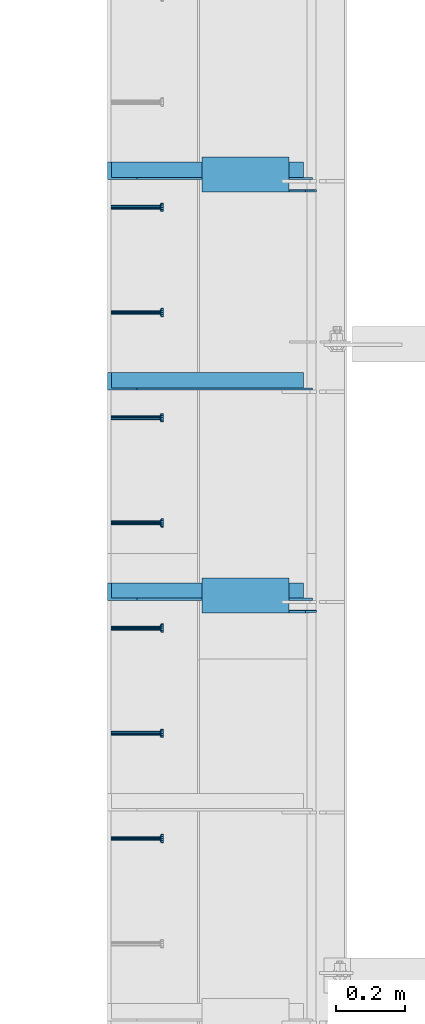
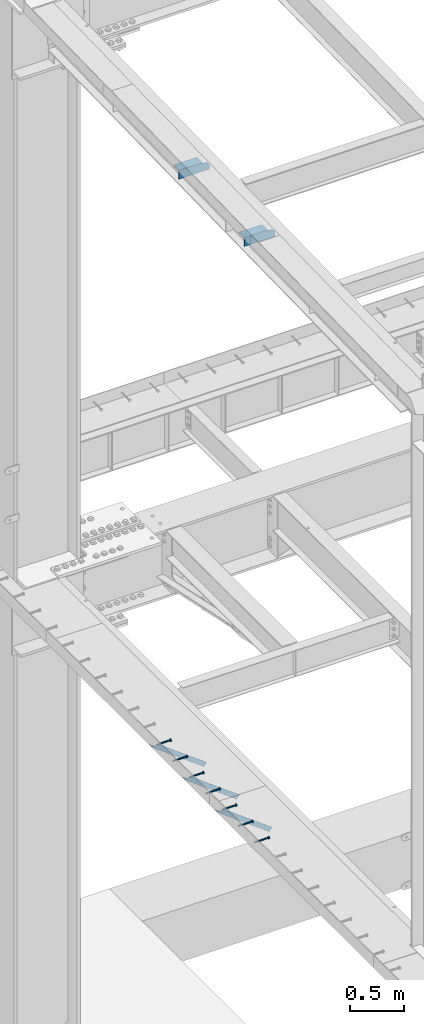
# One storey, part 1330 of 1763: 9 beams, 3 members, 9 elements without a shape of their own.
"""IFC2X3 building model written with IfcOpenShell, lengths in millimetres."""

from ifc_helpers import new_model, si_unit, frame, origin_with_axes, place, context, subcontext, project, spatial, faceted_brep, material, type_object, element, aggregate, save


model = new_model("IFC2X3")

# Units and contexts
model_context = context("Model", 3, precision=1e-05, world=origin_with_axes())
body_context = subcontext(model_context, "Body", "Model", "MODEL_VIEW")
ifc_project = project(units=[si_unit("LENGTHUNIT", "METRE", prefix="MILLI"), si_unit("AREAUNIT", "SQUARE_METRE"), si_unit("VOLUMEUNIT", "CUBIC_METRE"), si_unit("MASSUNIT", "GRAM", prefix="KILO"), si_unit("TIMEUNIT", "SECOND"), si_unit("PLANEANGLEUNIT", "RADIAN"), si_unit("SOLIDANGLEUNIT", "STERADIAN"), si_unit("THERMODYNAMICTEMPERATUREUNIT", "DEGREE_CELSIUS"), si_unit("LUMINOUSINTENSITYUNIT", "LUMEN")], contexts=[model_context])

# Site, building, storey
site_placement = place(None, origin_with_axes())
site = spatial("IfcSite", under=ifc_project, at=site_placement, CompositionType="ELEMENT")
building_placement = place(site_placement, origin_with_axes())
building = spatial("IfcBuilding", under=site, at=building_placement, Name="Undefined", CompositionType="ELEMENT")
storey_placement = place(building_placement, origin_with_axes())
storey = spatial("IfcBuildingStorey", under=building, at=storey_placement, Name="Undefined", CompositionType="ELEMENT", Elevation=0.0)

# Assembly, beam
assembly_1_placement = place(storey_placement, origin_with_axes())
assembly_1 = element("IfcElementAssembly", 1, at=assembly_1_placement, inside=storey, Name="HEADED STUD ANCHOR", AssemblyPlace="NOTDEFINED", PredefinedType="RIGID_FRAME")
ifc_material_1 = material(Name="STEEL/A108")
beam_type_1 = type_object("IfcBeamType", PredefinedType="NOTDEFINED")
beam_1_placement = place(assembly_1_placement, frame((-87975.5122736983, 47031.2750061035, 5268.91250001202), z_axis=(0.0, 0.0, -1.0), x_axis=(1.0, 0.0, 0.0)))
beam_1 = element("IfcBeam", 2, at=beam_1_placement, type_object=beam_type_1, material=ifc_material_1, Name="HEADED STUD ANCHOR", context=body_context, shape_type="Brep", body=[
    faceted_brep([(0.0, -3.1800000667572, 5.5), (0.0, -5.5, 3.1800000667572), (141.732000000002, -5.5, 3.1800000667572), (141.732000000002, -3.1800000667572, 5.5), (0.0, -6.34999999999491, 1.45519152283669e-11), (141.732000000002, -6.34999990463257, 0.0), (0.0, -5.5, -3.1800000667572), (141.732000000002, -5.5, -3.1800000667572), (0.0, -3.1800000667572, -5.5), (141.732000000002, -3.1800000667572, -5.5), (0.0, 0.0, -6.34999990463257), (141.732000000002, 0.0, -6.34999990463257), (0.0, 3.1800000667572, -5.5), (141.732000000002, 3.1800000667572, -5.5), (0.0, 5.5, -3.1800000667572), (141.732000000002, 5.5, -3.1800000667572), (0.0, 6.34999999999491, -2.91038304567337e-11), (141.732000000002, 6.34999990463257, 0.0), (0.0, 5.5, 3.1800000667572), (141.732000000002, 5.5, 3.1800000667572), (0.0, 3.1800000667572, 5.5), (141.732000000002, 3.1800000667572, 5.5), (0.0, 0.0, 6.34999990463257), (141.732000000002, 0.0, 6.34999990463257), (144.780000000001, -10.9899997711182, 6.34999990463257), (144.780000000001, -6.34000015258789, 10.9899997711182), (144.780000000001, -12.6999998092651, 0.0), (144.780000000001, -10.9899997711182, -6.34999990463257), (144.780000000001, -6.34000015258789, -10.9899997711182), (144.780000000001, 0.0, -12.6899995803833), (144.780000000001, 6.34000015258789, -10.9899997711182), (144.780000000001, 10.9899997711182, -6.34999990463257), (144.780000000001, 12.6999998092651, 0.0), (144.780000000001, 10.9899997711182, 6.34999990463257), (144.780000000001, 6.34000015258789, 10.9899997711182), (144.780000000001, 0.0, 12.6899995803833), (152.400000000001, -10.9899997711182, 6.34999990463257), (152.400000000001, -6.34000015258789, 10.9899997711182), (152.400000000001, -12.6999998092651, 0.0), (152.400000000001, -10.9899997711182, -6.34999990463257), (152.400000000001, -6.34000015258789, -10.9899997711182), (152.400000000001, 0.0, -12.6899995803833), (152.400000000001, 6.34000015258789, -10.9899997711182), (152.400000000001, 10.9899997711182, -6.34999990463257), (152.400000000001, 12.6999998092651, 0.0), (152.400000000001, 10.9899997711182, 6.34999990463257), (152.400000000001, 6.34000015258789, 10.9899997711182), (152.400000000001, 0.0, 12.6899995803833)], [[[0, 1, 2, 3]], [[1, 4, 5, 2]], [[4, 6, 7, 5]], [[6, 8, 9, 7]], [[8, 10, 11, 9]], [[10, 12, 13, 11]], [[12, 14, 15, 13]], [[14, 16, 17, 15]], [[16, 18, 19, 17]], [[18, 20, 21, 19]], [[20, 22, 23, 21]], [[22, 0, 3, 23]], [[22, 20, 18, 16, 14, 12, 10, 8, 6, 4, 1, 0]], [[3, 2, 24, 25]], [[2, 5, 26, 24]], [[5, 7, 27, 26]], [[7, 9, 28, 27]], [[9, 11, 29, 28]], [[11, 13, 30, 29]], [[13, 15, 31, 30]], [[15, 17, 32, 31]], [[17, 19, 33, 32]], [[19, 21, 34, 33]], [[21, 23, 35, 34]], [[23, 3, 25, 35]], [[25, 24, 36, 37]], [[24, 26, 38, 36]], [[26, 27, 39, 38]], [[27, 28, 40, 39]], [[28, 29, 41, 40]], [[29, 30, 42, 41]], [[30, 31, 43, 42]], [[31, 32, 44, 43]], [[32, 33, 45, 44]], [[33, 34, 46, 45]], [[34, 35, 47, 46]], [[35, 25, 37, 47]], [[38, 39, 40, 41, 42, 43, 44, 45, 46, 47, 37, 36]]]),
])
aggregate(assembly_1, [beam_1])

assembly_2_placement = place(storey_placement, origin_with_axes())
assembly_2 = element("IfcElementAssembly", 3, at=assembly_2_placement, inside=storey, Name="HEADED STUD ANCHOR", AssemblyPlace="NOTDEFINED", PredefinedType="RIGID_FRAME")
beam_2_placement = place(assembly_2_placement, frame((-87975.5122736983, 47336.0750061035, 5268.91250001202), z_axis=(0.0, 0.0, -1.0), x_axis=(1.0, 0.0, 0.0)))
beam_2 = element("IfcBeam", 4, at=beam_2_placement, type_object=beam_type_1, material=ifc_material_1, Name="HEADED STUD ANCHOR", context=body_context, shape_type="Brep", body=[
    faceted_brep([(0.0, -3.1800000667572, 5.5), (0.0, -5.5, 3.1800000667572), (141.732000000002, -5.5, 3.1800000667572), (141.732000000002, -3.1800000667572, 5.5), (0.0, -6.34999999999491, 1.45519152283669e-11), (141.732000000002, -6.34999990463257, 0.0), (0.0, -5.5, -3.1800000667572), (141.732000000002, -5.5, -3.1800000667572), (0.0, -3.1800000667572, -5.5), (141.732000000002, -3.1800000667572, -5.5), (0.0, 0.0, -6.34999990463257), (141.732000000002, 0.0, -6.34999990463257), (0.0, 3.1800000667572, -5.5), (141.732000000002, 3.1800000667572, -5.5), (0.0, 5.5, -3.1800000667572), (141.732000000002, 5.5, -3.1800000667572), (0.0, 6.34999999999491, -2.91038304567337e-11), (141.732000000002, 6.34999990463257, 0.0), (0.0, 5.5, 3.1800000667572), (141.732000000002, 5.5, 3.1800000667572), (0.0, 3.1800000667572, 5.5), (141.732000000002, 3.1800000667572, 5.5), (0.0, 0.0, 6.34999990463257), (141.732000000002, 0.0, 6.34999990463257), (144.780000000001, -10.9899997711182, 6.34999990463257), (144.780000000001, -6.34000015258789, 10.9899997711182), (144.780000000001, -12.6999998092651, 0.0), (144.780000000001, -10.9899997711182, -6.34999990463257), (144.780000000001, -6.34000015258789, -10.9899997711182), (144.780000000001, 0.0, -12.6899995803833), (144.780000000001, 6.34000015258789, -10.9899997711182), (144.780000000001, 10.9899997711182, -6.34999990463257), (144.780000000001, 12.6999998092651, 0.0), (144.780000000001, 10.9899997711182, 6.34999990463257), (144.780000000001, 6.34000015258789, 10.9899997711182), (144.780000000001, 0.0, 12.6899995803833), (152.400000000001, -10.9899997711182, 6.34999990463257), (152.400000000001, -6.34000015258789, 10.9899997711182), (152.400000000001, -12.6999998092651, 0.0), (152.400000000001, -10.9899997711182, -6.34999990463257), (152.400000000001, -6.34000015258789, -10.9899997711182), (152.400000000001, 0.0, -12.6899995803833), (152.400000000001, 6.34000015258789, -10.9899997711182), (152.400000000001, 10.9899997711182, -6.34999990463257), (152.400000000001, 12.6999998092651, 0.0), (152.400000000001, 10.9899997711182, 6.34999990463257), (152.400000000001, 6.34000015258789, 10.9899997711182), (152.400000000001, 0.0, 12.6899995803833)], [[[0, 1, 2, 3]], [[1, 4, 5, 2]], [[4, 6, 7, 5]], [[6, 8, 9, 7]], [[8, 10, 11, 9]], [[10, 12, 13, 11]], [[12, 14, 15, 13]], [[14, 16, 17, 15]], [[16, 18, 19, 17]], [[18, 20, 21, 19]], [[20, 22, 23, 21]], [[22, 0, 3, 23]], [[22, 20, 18, 16, 14, 12, 10, 8, 6, 4, 1, 0]], [[3, 2, 24, 25]], [[2, 5, 26, 24]], [[5, 7, 27, 26]], [[7, 9, 28, 27]], [[9, 11, 29, 28]], [[11, 13, 30, 29]], [[13, 15, 31, 30]], [[15, 17, 32, 31]], [[17, 19, 33, 32]], [[19, 21, 34, 33]], [[21, 23, 35, 34]], [[23, 3, 25, 35]], [[25, 24, 36, 37]], [[24, 26, 38, 36]], [[26, 27, 39, 38]], [[27, 28, 40, 39]], [[28, 29, 41, 40]], [[29, 30, 42, 41]], [[30, 31, 43, 42]], [[31, 32, 44, 43]], [[32, 33, 45, 44]], [[33, 34, 46, 45]], [[34, 35, 47, 46]], [[35, 25, 37, 47]], [[38, 39, 40, 41, 42, 43, 44, 45, 46, 47, 37, 36]]]),
])
aggregate(assembly_2, [beam_2])

assembly_3_placement = place(storey_placement, origin_with_axes())
assembly_3 = element("IfcElementAssembly", 5, at=assembly_3_placement, inside=storey, Name="HEADED STUD ANCHOR", AssemblyPlace="NOTDEFINED", PredefinedType="RIGID_FRAME")
beam_3_placement = place(assembly_3_placement, frame((-87975.5122736983, 47640.8750061035, 5268.91250001202), z_axis=(0.0, 0.0, -1.0), x_axis=(1.0, 0.0, 0.0)))
beam_3 = element("IfcBeam", 6, at=beam_3_placement, type_object=beam_type_1, material=ifc_material_1, Name="HEADED STUD ANCHOR", context=body_context, shape_type="Brep", body=[
    faceted_brep([(0.0, -3.1800000667572, 5.5), (0.0, -5.5, 3.1800000667572), (141.732000000002, -5.5, 3.1800000667572), (141.732000000002, -3.1800000667572, 5.5), (0.0, -6.34999999999491, 1.45519152283669e-11), (141.732000000002, -6.34999990463257, 0.0), (0.0, -5.5, -3.1800000667572), (141.732000000002, -5.5, -3.1800000667572), (0.0, -3.1800000667572, -5.5), (141.732000000002, -3.1800000667572, -5.5), (0.0, 0.0, -6.34999990463257), (141.732000000002, 0.0, -6.34999990463257), (0.0, 3.1800000667572, -5.5), (141.732000000002, 3.1800000667572, -5.5), (0.0, 5.5, -3.1800000667572), (141.732000000002, 5.5, -3.1800000667572), (0.0, 6.34999999999491, -2.91038304567337e-11), (141.732000000002, 6.34999990463257, 0.0), (0.0, 5.5, 3.1800000667572), (141.732000000002, 5.5, 3.1800000667572), (0.0, 3.1800000667572, 5.5), (141.732000000002, 3.1800000667572, 5.5), (0.0, 0.0, 6.34999990463257), (141.732000000002, 0.0, 6.34999990463257), (144.780000000001, -10.9899997711182, 6.34999990463257), (144.780000000001, -6.34000015258789, 10.9899997711182), (144.780000000001, -12.6999998092651, 0.0), (144.780000000001, -10.9899997711182, -6.34999990463257), (144.780000000001, -6.34000015258789, -10.9899997711182), (144.780000000001, 0.0, -12.6899995803833), (144.780000000001, 6.34000015258789, -10.9899997711182), (144.780000000001, 10.9899997711182, -6.34999990463257), (144.780000000001, 12.6999998092651, 0.0), (144.780000000001, 10.9899997711182, 6.34999990463257), (144.780000000001, 6.34000015258789, 10.9899997711182), (144.780000000001, 0.0, 12.6899995803833), (152.400000000001, -10.9899997711182, 6.34999990463257), (152.400000000001, -6.34000015258789, 10.9899997711182), (152.400000000001, -12.6999998092651, 0.0), (152.400000000001, -10.9899997711182, -6.34999990463257), (152.400000000001, -6.34000015258789, -10.9899997711182), (152.400000000001, 0.0, -12.6899995803833), (152.400000000001, 6.34000015258789, -10.9899997711182), (152.400000000001, 10.9899997711182, -6.34999990463257), (152.400000000001, 12.6999998092651, 0.0), (152.400000000001, 10.9899997711182, 6.34999990463257), (152.400000000001, 6.34000015258789, 10.9899997711182), (152.400000000001, 0.0, 12.6899995803833)], [[[0, 1, 2, 3]], [[1, 4, 5, 2]], [[4, 6, 7, 5]], [[6, 8, 9, 7]], [[8, 10, 11, 9]], [[10, 12, 13, 11]], [[12, 14, 15, 13]], [[14, 16, 17, 15]], [[16, 18, 19, 17]], [[18, 20, 21, 19]], [[20, 22, 23, 21]], [[22, 0, 3, 23]], [[22, 20, 18, 16, 14, 12, 10, 8, 6, 4, 1, 0]], [[3, 2, 24, 25]], [[2, 5, 26, 24]], [[5, 7, 27, 26]], [[7, 9, 28, 27]], [[9, 11, 29, 28]], [[11, 13, 30, 29]], [[13, 15, 31, 30]], [[15, 17, 32, 31]], [[17, 19, 33, 32]], [[19, 21, 34, 33]], [[21, 23, 35, 34]], [[23, 3, 25, 35]], [[25, 24, 36, 37]], [[24, 26, 38, 36]], [[26, 27, 39, 38]], [[27, 28, 40, 39]], [[28, 29, 41, 40]], [[29, 30, 42, 41]], [[30, 31, 43, 42]], [[31, 32, 44, 43]], [[32, 33, 45, 44]], [[33, 34, 46, 45]], [[34, 35, 47, 46]], [[35, 25, 37, 47]], [[38, 39, 40, 41, 42, 43, 44, 45, 46, 47, 37, 36]]]),
])
aggregate(assembly_3, [beam_3])

assembly_4_placement = place(storey_placement, origin_with_axes())
assembly_4 = element("IfcElementAssembly", 7, at=assembly_4_placement, inside=storey, Name="HEADED STUD ANCHOR", AssemblyPlace="NOTDEFINED", PredefinedType="RIGID_FRAME")
beam_4_placement = place(assembly_4_placement, frame((-87975.5122736983, 47945.6750061035, 5268.91250001202), z_axis=(0.0, 0.0, -1.0), x_axis=(1.0, 0.0, 0.0)))
beam_4 = element("IfcBeam", 8, at=beam_4_placement, type_object=beam_type_1, material=ifc_material_1, Name="HEADED STUD ANCHOR", context=body_context, shape_type="Brep", body=[
    faceted_brep([(0.0, -3.1800000667572, 5.5), (0.0, -5.5, 3.1800000667572), (141.732000000002, -5.5, 3.1800000667572), (141.732000000002, -3.1800000667572, 5.5), (0.0, -6.34999999999491, 1.45519152283669e-11), (141.732000000002, -6.34999990463257, 0.0), (0.0, -5.5, -3.1800000667572), (141.732000000002, -5.5, -3.1800000667572), (0.0, -3.1800000667572, -5.5), (141.732000000002, -3.1800000667572, -5.5), (0.0, 0.0, -6.34999990463257), (141.732000000002, 0.0, -6.34999990463257), (0.0, 3.1800000667572, -5.5), (141.732000000002, 3.1800000667572, -5.5), (0.0, 5.5, -3.1800000667572), (141.732000000002, 5.5, -3.1800000667572), (0.0, 6.34999999999491, -2.91038304567337e-11), (141.732000000002, 6.34999990463257, 0.0), (0.0, 5.5, 3.1800000667572), (141.732000000002, 5.5, 3.1800000667572), (0.0, 3.1800000667572, 5.5), (141.732000000002, 3.1800000667572, 5.5), (0.0, 0.0, 6.34999990463257), (141.732000000002, 0.0, 6.34999990463257), (144.780000000001, -10.9899997711182, 6.34999990463257), (144.780000000001, -6.34000015258789, 10.9899997711182), (144.780000000001, -12.6999998092651, 0.0), (144.780000000001, -10.9899997711182, -6.34999990463257), (144.780000000001, -6.34000015258789, -10.9899997711182), (144.780000000001, 0.0, -12.6899995803833), (144.780000000001, 6.34000015258789, -10.9899997711182), (144.780000000001, 10.9899997711182, -6.34999990463257), (144.780000000001, 12.6999998092651, 0.0), (144.780000000001, 10.9899997711182, 6.34999990463257), (144.780000000001, 6.34000015258789, 10.9899997711182), (144.780000000001, 0.0, 12.6899995803833), (152.400000000001, -10.9899997711182, 6.34999990463257), (152.400000000001, -6.34000015258789, 10.9899997711182), (152.400000000001, -12.6999998092651, 0.0), (152.400000000001, -10.9899997711182, -6.34999990463257), (152.400000000001, -6.34000015258789, -10.9899997711182), (152.400000000001, 0.0, -12.6899995803833), (152.400000000001, 6.34000015258789, -10.9899997711182), (152.400000000001, 10.9899997711182, -6.34999990463257), (152.400000000001, 12.6999998092651, 0.0), (152.400000000001, 10.9899997711182, 6.34999990463257), (152.400000000001, 6.34000015258789, 10.9899997711182), (152.400000000001, 0.0, 12.6899995803833)], [[[0, 1, 2, 3]], [[1, 4, 5, 2]], [[4, 6, 7, 5]], [[6, 8, 9, 7]], [[8, 10, 11, 9]], [[10, 12, 13, 11]], [[12, 14, 15, 13]], [[14, 16, 17, 15]], [[16, 18, 19, 17]], [[18, 20, 21, 19]], [[20, 22, 23, 21]], [[22, 0, 3, 23]], [[22, 20, 18, 16, 14, 12, 10, 8, 6, 4, 1, 0]], [[3, 2, 24, 25]], [[2, 5, 26, 24]], [[5, 7, 27, 26]], [[7, 9, 28, 27]], [[9, 11, 29, 28]], [[11, 13, 30, 29]], [[13, 15, 31, 30]], [[15, 17, 32, 31]], [[17, 19, 33, 32]], [[19, 21, 34, 33]], [[21, 23, 35, 34]], [[23, 3, 25, 35]], [[25, 24, 36, 37]], [[24, 26, 38, 36]], [[26, 27, 39, 38]], [[27, 28, 40, 39]], [[28, 29, 41, 40]], [[29, 30, 42, 41]], [[30, 31, 43, 42]], [[31, 32, 44, 43]], [[32, 33, 45, 44]], [[33, 34, 46, 45]], [[34, 35, 47, 46]], [[35, 25, 37, 47]], [[38, 39, 40, 41, 42, 43, 44, 45, 46, 47, 37, 36]]]),
])
aggregate(assembly_4, [beam_4])

assembly_5_placement = place(storey_placement, origin_with_axes())
assembly_5 = element("IfcElementAssembly", 9, at=assembly_5_placement, inside=storey, Name="HEADED STUD ANCHOR", AssemblyPlace="NOTDEFINED", PredefinedType="RIGID_FRAME")
beam_5_placement = place(assembly_5_placement, frame((-87975.5122736983, 48250.4750061035, 5268.91250001202), z_axis=(0.0, 0.0, -1.0), x_axis=(1.0, 0.0, 0.0)))
beam_5 = element("IfcBeam", 10, at=beam_5_placement, type_object=beam_type_1, material=ifc_material_1, Name="HEADED STUD ANCHOR", context=body_context, shape_type="Brep", body=[
    faceted_brep([(0.0, -3.1800000667572, 5.5), (0.0, -5.5, 3.1800000667572), (141.732000000002, -5.5, 3.1800000667572), (141.732000000002, -3.1800000667572, 5.5), (0.0, -6.34999999999491, 1.45519152283669e-11), (141.732000000002, -6.34999990463257, 0.0), (0.0, -5.5, -3.1800000667572), (141.732000000002, -5.5, -3.1800000667572), (0.0, -3.1800000667572, -5.5), (141.732000000002, -3.1800000667572, -5.5), (0.0, 0.0, -6.34999990463257), (141.732000000002, 0.0, -6.34999990463257), (0.0, 3.1800000667572, -5.5), (141.732000000002, 3.1800000667572, -5.5), (0.0, 5.5, -3.1800000667572), (141.732000000002, 5.5, -3.1800000667572), (0.0, 6.34999999999491, -2.91038304567337e-11), (141.732000000002, 6.34999990463257, 0.0), (0.0, 5.5, 3.1800000667572), (141.732000000002, 5.5, 3.1800000667572), (0.0, 3.1800000667572, 5.5), (141.732000000002, 3.1800000667572, 5.5), (0.0, 0.0, 6.34999990463257), (141.732000000002, 0.0, 6.34999990463257), (144.780000000001, -10.9899997711182, 6.34999990463257), (144.780000000001, -6.34000015258789, 10.9899997711182), (144.780000000001, -12.6999998092651, 0.0), (144.780000000001, -10.9899997711182, -6.34999990463257), (144.780000000001, -6.34000015258789, -10.9899997711182), (144.780000000001, 0.0, -12.6899995803833), (144.780000000001, 6.34000015258789, -10.9899997711182), (144.780000000001, 10.9899997711182, -6.34999990463257), (144.780000000001, 12.6999998092651, 0.0), (144.780000000001, 10.9899997711182, 6.34999990463257), (144.780000000001, 6.34000015258789, 10.9899997711182), (144.780000000001, 0.0, 12.6899995803833), (152.400000000001, -10.9899997711182, 6.34999990463257), (152.400000000001, -6.34000015258789, 10.9899997711182), (152.400000000001, -12.6999998092651, 0.0), (152.400000000001, -10.9899997711182, -6.34999990463257), (152.400000000001, -6.34000015258789, -10.9899997711182), (152.400000000001, 0.0, -12.6899995803833), (152.400000000001, 6.34000015258789, -10.9899997711182), (152.400000000001, 10.9899997711182, -6.34999990463257), (152.400000000001, 12.6999998092651, 0.0), (152.400000000001, 10.9899997711182, 6.34999990463257), (152.400000000001, 6.34000015258789, 10.9899997711182), (152.400000000001, 0.0, 12.6899995803833)], [[[0, 1, 2, 3]], [[1, 4, 5, 2]], [[4, 6, 7, 5]], [[6, 8, 9, 7]], [[8, 10, 11, 9]], [[10, 12, 13, 11]], [[12, 14, 15, 13]], [[14, 16, 17, 15]], [[16, 18, 19, 17]], [[18, 20, 21, 19]], [[20, 22, 23, 21]], [[22, 0, 3, 23]], [[22, 20, 18, 16, 14, 12, 10, 8, 6, 4, 1, 0]], [[3, 2, 24, 25]], [[2, 5, 26, 24]], [[5, 7, 27, 26]], [[7, 9, 28, 27]], [[9, 11, 29, 28]], [[11, 13, 30, 29]], [[13, 15, 31, 30]], [[15, 17, 32, 31]], [[17, 19, 33, 32]], [[19, 21, 34, 33]], [[21, 23, 35, 34]], [[23, 3, 25, 35]], [[25, 24, 36, 37]], [[24, 26, 38, 36]], [[26, 27, 39, 38]], [[27, 28, 40, 39]], [[28, 29, 41, 40]], [[29, 30, 42, 41]], [[30, 31, 43, 42]], [[31, 32, 44, 43]], [[32, 33, 45, 44]], [[33, 34, 46, 45]], [[34, 35, 47, 46]], [[35, 25, 37, 47]], [[38, 39, 40, 41, 42, 43, 44, 45, 46, 47, 37, 36]]]),
])
aggregate(assembly_5, [beam_5])

assembly_6_placement = place(storey_placement, origin_with_axes())
assembly_6 = element("IfcElementAssembly", 11, at=assembly_6_placement, inside=storey, Name="HEADED STUD ANCHOR", AssemblyPlace="NOTDEFINED", PredefinedType="RIGID_FRAME")
beam_6_placement = place(assembly_6_placement, frame((-87975.5122736983, 48555.2750061035, 5268.91250001202), z_axis=(0.0, 0.0, -1.0), x_axis=(1.0, 0.0, 0.0)))
beam_6 = element("IfcBeam", 12, at=beam_6_placement, type_object=beam_type_1, material=ifc_material_1, Name="HEADED STUD ANCHOR", context=body_context, shape_type="Brep", body=[
    faceted_brep([(0.0, -3.1800000667572, 5.5), (0.0, -5.5, 3.1800000667572), (141.732000000002, -5.5, 3.1800000667572), (141.732000000002, -3.1800000667572, 5.5), (0.0, -6.34999999999491, 1.45519152283669e-11), (141.732000000002, -6.34999990463257, 0.0), (0.0, -5.5, -3.1800000667572), (141.732000000002, -5.5, -3.1800000667572), (0.0, -3.1800000667572, -5.5), (141.732000000002, -3.1800000667572, -5.5), (0.0, 0.0, -6.34999990463257), (141.732000000002, 0.0, -6.34999990463257), (0.0, 3.1800000667572, -5.5), (141.732000000002, 3.1800000667572, -5.5), (0.0, 5.5, -3.1800000667572), (141.732000000002, 5.5, -3.1800000667572), (0.0, 6.34999999999491, -2.91038304567337e-11), (141.732000000002, 6.34999990463257, 0.0), (0.0, 5.5, 3.1800000667572), (141.732000000002, 5.5, 3.1800000667572), (0.0, 3.1800000667572, 5.5), (141.732000000002, 3.1800000667572, 5.5), (0.0, 0.0, 6.34999990463257), (141.732000000002, 0.0, 6.34999990463257), (144.780000000001, -10.9899997711182, 6.34999990463257), (144.780000000001, -6.34000015258789, 10.9899997711182), (144.780000000001, -12.6999998092651, 0.0), (144.780000000001, -10.9899997711182, -6.34999990463257), (144.780000000001, -6.34000015258789, -10.9899997711182), (144.780000000001, 0.0, -12.6899995803833), (144.780000000001, 6.34000015258789, -10.9899997711182), (144.780000000001, 10.9899997711182, -6.34999990463257), (144.780000000001, 12.6999998092651, 0.0), (144.780000000001, 10.9899997711182, 6.34999990463257), (144.780000000001, 6.34000015258789, 10.9899997711182), (144.780000000001, 0.0, 12.6899995803833), (152.400000000001, -10.9899997711182, 6.34999990463257), (152.400000000001, -6.34000015258789, 10.9899997711182), (152.400000000001, -12.6999998092651, 0.0), (152.400000000001, -10.9899997711182, -6.34999990463257), (152.400000000001, -6.34000015258789, -10.9899997711182), (152.400000000001, 0.0, -12.6899995803833), (152.400000000001, 6.34000015258789, -10.9899997711182), (152.400000000001, 10.9899997711182, -6.34999990463257), (152.400000000001, 12.6999998092651, 0.0), (152.400000000001, 10.9899997711182, 6.34999990463257), (152.400000000001, 6.34000015258789, 10.9899997711182), (152.400000000001, 0.0, 12.6899995803833)], [[[0, 1, 2, 3]], [[1, 4, 5, 2]], [[4, 6, 7, 5]], [[6, 8, 9, 7]], [[8, 10, 11, 9]], [[10, 12, 13, 11]], [[12, 14, 15, 13]], [[14, 16, 17, 15]], [[16, 18, 19, 17]], [[18, 20, 21, 19]], [[20, 22, 23, 21]], [[22, 0, 3, 23]], [[22, 20, 18, 16, 14, 12, 10, 8, 6, 4, 1, 0]], [[3, 2, 24, 25]], [[2, 5, 26, 24]], [[5, 7, 27, 26]], [[7, 9, 28, 27]], [[9, 11, 29, 28]], [[11, 13, 30, 29]], [[13, 15, 31, 30]], [[15, 17, 32, 31]], [[17, 19, 33, 32]], [[19, 21, 34, 33]], [[21, 23, 35, 34]], [[23, 3, 25, 35]], [[25, 24, 36, 37]], [[24, 26, 38, 36]], [[26, 27, 39, 38]], [[27, 28, 40, 39]], [[28, 29, 41, 40]], [[29, 30, 42, 41]], [[30, 31, 43, 42]], [[31, 32, 44, 43]], [[32, 33, 45, 44]], [[33, 34, 46, 45]], [[34, 35, 47, 46]], [[35, 25, 37, 47]], [[38, 39, 40, 41, 42, 43, 44, 45, 46, 47, 37, 36]]]),
])
aggregate(assembly_6, [beam_6])

assembly_7_placement = place(storey_placement, origin_with_axes())
assembly_7 = element("IfcElementAssembly", 13, at=assembly_7_placement, inside=storey, Name="HEADED STUD ANCHOR", AssemblyPlace="NOTDEFINED", PredefinedType="RIGID_FRAME")
beam_7_placement = place(assembly_7_placement, frame((-87975.5122736983, 48860.0750061035, 5268.91250001202), z_axis=(0.0, 0.0, -1.0), x_axis=(1.0, 0.0, 0.0)))
beam_7 = element("IfcBeam", 14, at=beam_7_placement, type_object=beam_type_1, material=ifc_material_1, Name="HEADED STUD ANCHOR", context=body_context, shape_type="Brep", body=[
    faceted_brep([(0.0, -3.1800000667572, 5.5), (0.0, -5.5, 3.1800000667572), (141.732000000002, -5.5, 3.1800000667572), (141.732000000002, -3.1800000667572, 5.5), (0.0, -6.34999999999491, 1.45519152283669e-11), (141.732000000002, -6.34999990463257, 0.0), (0.0, -5.5, -3.1800000667572), (141.732000000002, -5.5, -3.1800000667572), (0.0, -3.1800000667572, -5.5), (141.732000000002, -3.1800000667572, -5.5), (0.0, 0.0, -6.34999990463257), (141.732000000002, 0.0, -6.34999990463257), (0.0, 3.1800000667572, -5.5), (141.732000000002, 3.1800000667572, -5.5), (0.0, 5.5, -3.1800000667572), (141.732000000002, 5.5, -3.1800000667572), (0.0, 6.34999999999491, -2.91038304567337e-11), (141.732000000002, 6.34999990463257, 0.0), (0.0, 5.5, 3.1800000667572), (141.732000000002, 5.5, 3.1800000667572), (0.0, 3.1800000667572, 5.5), (141.732000000002, 3.1800000667572, 5.5), (0.0, 0.0, 6.34999990463257), (141.732000000002, 0.0, 6.34999990463257), (144.780000000001, -10.9899997711182, 6.34999990463257), (144.780000000001, -6.34000015258789, 10.9899997711182), (144.780000000001, -12.6999998092651, 0.0), (144.780000000001, -10.9899997711182, -6.34999990463257), (144.780000000001, -6.34000015258789, -10.9899997711182), (144.780000000001, 0.0, -12.6899995803833), (144.780000000001, 6.34000015258789, -10.9899997711182), (144.780000000001, 10.9899997711182, -6.34999990463257), (144.780000000001, 12.6999998092651, 0.0), (144.780000000001, 10.9899997711182, 6.34999990463257), (144.780000000001, 6.34000015258789, 10.9899997711182), (144.780000000001, 0.0, 12.6899995803833), (152.400000000001, -10.9899997711182, 6.34999990463257), (152.400000000001, -6.34000015258789, 10.9899997711182), (152.400000000001, -12.6999998092651, 0.0), (152.400000000001, -10.9899997711182, -6.34999990463257), (152.400000000001, -6.34000015258789, -10.9899997711182), (152.400000000001, 0.0, -12.6899995803833), (152.400000000001, 6.34000015258789, -10.9899997711182), (152.400000000001, 10.9899997711182, -6.34999990463257), (152.400000000001, 12.6999998092651, 0.0), (152.400000000001, 10.9899997711182, 6.34999990463257), (152.400000000001, 6.34000015258789, 10.9899997711182), (152.400000000001, 0.0, 12.6899995803833)], [[[0, 1, 2, 3]], [[1, 4, 5, 2]], [[4, 6, 7, 5]], [[6, 8, 9, 7]], [[8, 10, 11, 9]], [[10, 12, 13, 11]], [[12, 14, 15, 13]], [[14, 16, 17, 15]], [[16, 18, 19, 17]], [[18, 20, 21, 19]], [[20, 22, 23, 21]], [[22, 0, 3, 23]], [[22, 20, 18, 16, 14, 12, 10, 8, 6, 4, 1, 0]], [[3, 2, 24, 25]], [[2, 5, 26, 24]], [[5, 7, 27, 26]], [[7, 9, 28, 27]], [[9, 11, 29, 28]], [[11, 13, 30, 29]], [[13, 15, 31, 30]], [[15, 17, 32, 31]], [[17, 19, 33, 32]], [[19, 21, 34, 33]], [[21, 23, 35, 34]], [[23, 3, 25, 35]], [[25, 24, 36, 37]], [[24, 26, 38, 36]], [[26, 27, 39, 38]], [[27, 28, 40, 39]], [[28, 29, 41, 40]], [[29, 30, 42, 41]], [[30, 31, 43, 42]], [[31, 32, 44, 43]], [[32, 33, 45, 44]], [[33, 34, 46, 45]], [[34, 35, 47, 46]], [[35, 25, 37, 47]], [[38, 39, 40, 41, 42, 43, 44, 45, 46, 47, 37, 36]]]),
])
aggregate(assembly_7, [beam_7])

# Assembly, members
assembly_8_placement = place(storey_placement, origin_with_axes())
assembly_8 = element("IfcElementAssembly", 15, at=assembly_8_placement, inside=storey, Name="BEAM", AssemblyPlace="NOTDEFINED", PredefinedType="RIGID_FRAME")
ifc_material_2 = material(Name="STEEL/A36")
member_type = type_object("IfcMemberType", Name="L2X2X1/4", PredefinedType="NOTDEFINED")
member_1_placement = place(assembly_8_placement, frame((-87406.0995933455, 48356.04375, 4794.78284113776), z_axis=(0.597323303215295, 0.0, 0.802000543289074), x_axis=(-0.802000543289071, 0.0, 0.597323303215297)))
member_1 = element("IfcMember", 16, at=member_1_placement, type_object=member_type, material=ifc_material_2, Name="ANGLE", ObjectType="L2X2X1/4", context=body_context, shape_type="Brep", body=[
    faceted_brep([(-1.45519152283669e-11, 25.4000000000015, -25.3999999999869), (1.45519152283669e-11, 25.4000000000015, 25.3999999999796), (634.74226311341, 25.4000000000015, 25.3999999990119), (702.949257616929, 25.4000000000015, -25.4000000010055), (1.45519152283669e-11, 19.0499999999993, 25.3999999999796), (634.74226311341, 19.0500000000029, 25.3999999990119), (-7.27595761418343e-12, 19.0499999999993, -19.0499999999956), (694.423383303991, 19.0500000000029, -19.050000001007), (-7.27595761418343e-12, -25.4000000000015, -19.0499999999956), (694.423383303991, -25.4000000000015, -19.050000001007), (-1.45519152283669e-11, -25.4000000000015, -25.3999999999869), (702.949257616929, -25.4000000000015, -25.4000000010055)], [[[0, 1, 2, 3]], [[1, 4, 5, 2]], [[4, 6, 7, 5]], [[6, 8, 9, 7]], [[8, 10, 11, 9]], [[10, 0, 3, 11]], [[5, 7, 9, 11, 3, 2]], [[10, 8, 6, 4, 1, 0]]]),
])
member_2_placement = place(assembly_8_placement, frame((-87406.0995933455, 47746.44375, 4794.78284113776), z_axis=(0.597323303215295, 0.0, 0.802000543289074), x_axis=(-0.802000543289071, 0.0, 0.597323303215297)))
member_2 = element("IfcMember", 17, at=member_2_placement, type_object=member_type, material=ifc_material_2, Name="ANGLE", ObjectType="L2X2X1/4", context=body_context, shape_type="Brep", body=[
    faceted_brep([(-1.45519152283669e-11, 25.4000000000015, -25.3999999999869), (1.45519152283669e-11, 25.4000000000015, 25.3999999999796), (634.74226311341, 25.4000000000015, 25.3999999990119), (702.949257616929, 25.4000000000015, -25.4000000010055), (1.45519152283669e-11, 19.0499999999993, 25.3999999999796), (634.74226311341, 19.0500000000029, 25.3999999990119), (-7.27595761418343e-12, 19.0499999999993, -19.0499999999956), (694.423383303991, 19.0500000000029, -19.050000001007), (-7.27595761418343e-12, -25.4000000000015, -19.0499999999956), (694.423383303991, -25.4000000000015, -19.050000001007), (-1.45519152283669e-11, -25.4000000000015, -25.3999999999869), (702.949257616929, -25.4000000000015, -25.4000000010055)], [[[0, 1, 2, 3]], [[1, 4, 5, 2]], [[4, 6, 7, 5]], [[6, 8, 9, 7]], [[8, 10, 11, 9]], [[10, 0, 3, 11]], [[5, 7, 9, 11, 3, 2]], [[10, 8, 6, 4, 1, 0]]]),
])
member_3_placement = place(assembly_8_placement, frame((-87406.0995933455, 48965.64375, 4794.78284113776), z_axis=(0.597323303215295, 0.0, 0.802000543289074), x_axis=(-0.802000543289071, 0.0, 0.597323303215297)))
member_3 = element("IfcMember", 18, at=member_3_placement, type_object=member_type, material=ifc_material_2, Name="ANGLE", ObjectType="L2X2X1/4", context=body_context, shape_type="Brep", body=[
    faceted_brep([(-1.45519152283669e-11, 25.4000000000015, -25.3999999999869), (1.45519152283669e-11, 25.4000000000015, 25.3999999999796), (634.74226311341, 25.4000000000015, 25.3999999990119), (702.949257616929, 25.4000000000015, -25.4000000010055), (1.45519152283669e-11, 19.0499999999993, 25.3999999999796), (634.74226311341, 19.0500000000029, 25.3999999990119), (-7.27595761418343e-12, 19.0499999999993, -19.0499999999956), (694.423383303991, 19.0500000000029, -19.050000001007), (-7.27595761418343e-12, -25.4000000000015, -19.0499999999956), (694.423383303991, -25.4000000000015, -19.050000001007), (-1.45519152283669e-11, -25.4000000000015, -25.3999999999869), (702.949257616929, -25.4000000000015, -25.4000000010055)], [[[0, 1, 2, 3]], [[1, 4, 5, 2]], [[4, 6, 7, 5]], [[6, 8, 9, 7]], [[8, 10, 11, 9]], [[10, 0, 3, 11]], [[5, 7, 9, 11, 3, 2]], [[10, 8, 6, 4, 1, 0]]]),
])
aggregate(assembly_8, [member_1, member_2, member_3])

# Assembly, beams
assembly_9_placement = place(storey_placement, origin_with_axes())
assembly_9 = element("IfcElementAssembly", 19, at=assembly_9_placement, inside=storey, Name="BEAM", AssemblyPlace="NOTDEFINED", PredefinedType="RIGID_FRAME")
beam_type_2 = type_object("IfcBeamType", Name="L4X4X1/4", PredefinedType="NOTDEFINED")
beam_8_placement = place(assembly_9_placement, frame((-87711.9872706463, 48955.5242285613, 11631.200657095), z_axis=(0.0, 0.0206852279954837, -0.999786037781472), x_axis=(1.0, 0.0, 0.0)))
beam_8 = element("IfcBeam", 20, at=beam_8_placement, type_object=beam_type_2, material=ifc_material_2, Name="BRACE", ObjectType="L4X4X1/4", context=body_context, shape_type="Brep", body=[
    faceted_brep([(331.787533980634, 44.4500000001281, -4.76249998546336), (300.037521174891, 44.4500000001135, -36.4878036928512), (300.037521174891, 50.8000000001412, -36.4878037045546), (331.787546948486, 50.8000000001412, -4.76249998546518), (1.96450855582952e-10, -50.8000000000338, -44.4499999999534), (2.11002770811319e-10, -50.8000000000357, -50.799999999952), (252.412497029261, -50.800000000163, -50.7999999999502), (252.412491263516, -50.800000000163, -44.4499999999534), (-3.63797880709171e-11, 50.8000000000011, -50.8000000000538), (252.41249694943, 50.8000000001412, -50.7999999999756), (252.412491188385, 44.4500000001135, -44.4499999999807), (252.41248397647, 50.8000000001339, -36.5124986658775), (252.412483981447, 44.4500000001135, -36.5124986595329), (-2.18278728425503e-11, 44.4500000000007, -44.450000000048), (-1.81898940354586e-10, 44.4500000000371, 50.7999999999374), (-1.96450855582952e-10, 50.8000000000393, 50.7999999999374), (331.787546948486, 44.4500000001353, 50.7999999999502), (331.787546948486, 50.8000000001557, 50.7999999999465)], [[[0, 1, 2, 3]], [[4, 5, 6, 7]], [[5, 8, 9, 6]], [[10, 7, 6, 9, 11, 12]], [[13, 4, 7, 10]], [[5, 4, 13, 14, 15, 8]], [[15, 14, 16, 17]], [[17, 16, 0, 3]], [[11, 9, 8, 15, 17, 3, 2]], [[12, 11, 2, 1]], [[16, 14, 13, 10, 12, 1, 0]]]),
])
beam_9_placement = place(assembly_9_placement, frame((-87711.9872706465, 47736.5850912981, 11605.9812271231), z_axis=(0.0, 0.0206852279954837, -0.999786037781472), x_axis=(1.0, 0.0, 0.0)))
beam_9 = element("IfcBeam", 21, at=beam_9_placement, type_object=beam_type_2, material=ifc_material_2, Name="BRACE", ObjectType="L4X4X1/4", context=body_context, shape_type="Brep", body=[
    faceted_brep([(252.412491188385, 44.4500000001135, -44.4499999999807), (252.412491263516, -50.800000000163, -44.4499999999534), (252.412497029261, -50.800000000163, -50.7999999999502), (252.41249694943, 50.8000000001412, -50.7999999999756), (252.41248397647, 50.8000000001339, -36.5124986658775), (252.412483981447, 44.4500000001135, -36.5124986595329), (300.037533980634, 44.4500000001208, -36.5124999853924), (300.037533980634, 50.8000000001339, -36.5124999853942), (2.11002770811319e-10, -50.8000000000357, -50.799999999952), (1.96450855582952e-10, -50.8000000000338, -44.4499999999534), (-2.18278728425503e-11, 44.4500000000007, -44.450000000048), (-1.81898940354586e-10, 44.4500000000371, 50.7999999999374), (-1.96450855582952e-10, 50.8000000000393, 50.7999999999374), (-3.63797880709171e-11, 50.8000000000011, -50.8000000000538), (331.787546948486, 44.4500000001353, 50.7999999999502), (331.787546948486, 50.8000000001557, 50.7999999999465), (331.787533980634, 44.4500000001281, -4.76249998546336), (331.787546948486, 50.8000000001412, -4.76249998546518)], [[[0, 1, 2, 3, 4, 5]], [[6, 5, 4, 7]], [[8, 9, 10, 11, 12, 13]], [[12, 11, 14, 15]], [[15, 14, 16, 17]], [[17, 16, 6, 7]], [[3, 13, 12, 15, 17, 7, 4]], [[8, 13, 3, 2]], [[9, 8, 2, 1]], [[10, 9, 1, 0]], [[16, 14, 11, 10, 0, 5, 6]]]),
])
aggregate(assembly_9, [beam_8, beam_9])

save(model, "model.ifc")
